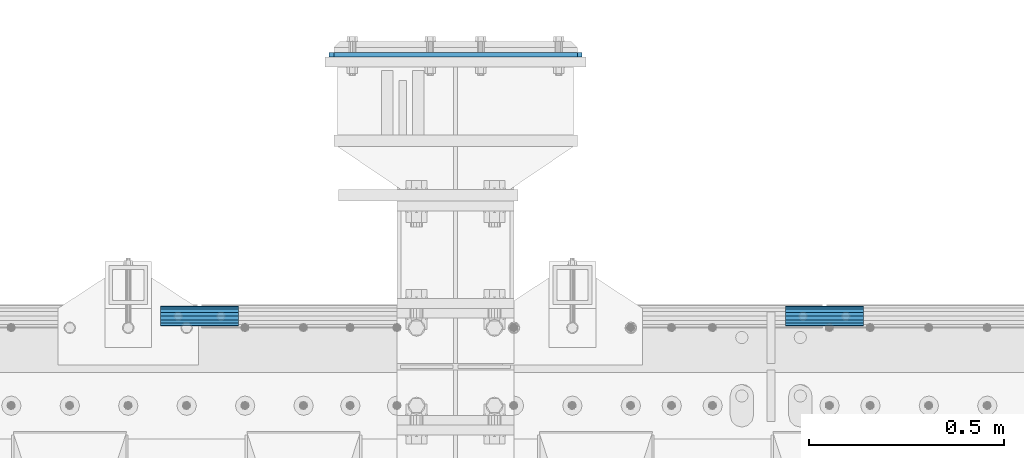
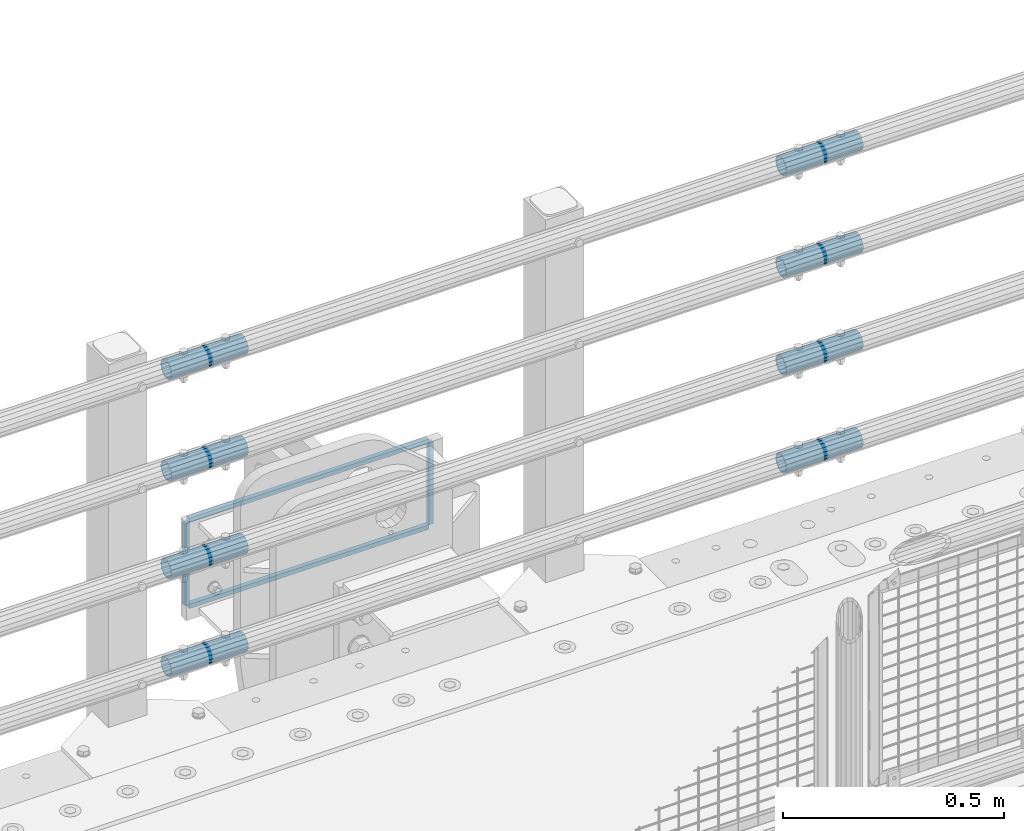
# One storey, part 165 of 240: 12 beams.
"""IFC2X3 building model written with IfcOpenShell, lengths in millimetres."""

from ifc_helpers import new_model, si_unit, frame, origin_with_axes, place, context, subcontext, project, spatial, faceted_brep, material, type_object, element, save


model = new_model("IFC2X3")

# Units and contexts
model_context = context("Model", 3, precision=1e-05, world=origin_with_axes())
body_context = subcontext(model_context, "Body", "Model", "MODEL_VIEW")
ifc_project = project(units=[si_unit("LENGTHUNIT", "METRE", prefix="MILLI"), si_unit("AREAUNIT", "SQUARE_METRE"), si_unit("VOLUMEUNIT", "CUBIC_METRE"), si_unit("MASSUNIT", "GRAM", prefix="KILO"), si_unit("TIMEUNIT", "SECOND"), si_unit("PLANEANGLEUNIT", "RADIAN"), si_unit("SOLIDANGLEUNIT", "STERADIAN"), si_unit("THERMODYNAMICTEMPERATUREUNIT", "DEGREE_CELSIUS"), si_unit("LUMINOUSINTENSITYUNIT", "LUMEN")], contexts=[model_context])

# Site, building, storey
site_placement = place(None, origin_with_axes())
site = spatial("IfcSite", under=ifc_project, at=site_placement, CompositionType="ELEMENT")
building_placement = place(site_placement, origin_with_axes())
building = spatial("IfcBuilding", under=site, at=building_placement, Name="Standard", CompositionType="ELEMENT")
storey_placement = place(building_placement, origin_with_axes())
storey = spatial("IfcBuildingStorey", under=building, at=storey_placement, Name="Undefined", CompositionType="ELEMENT", Elevation=0.0)

# Beams
ifc_material_1 = material(Name="STEEL/S355N")
beam_type_1 = type_object("IfcBeamType", PredefinedType="NOTDEFINED")
for number, where, z_axis, x_axis in (
    (1, (52521.4999999949, 36801.0000000349, -12.5000182222742), (-1.0, 0.0, 0.0), (0.0, 0.0, -1.0)),
    (2, (53158.5, 36801.0000000345, -12.500018222274), (-1.0, 0.0, 0.0), (0.0, 0.0, -1.0)),
):
    element("IfcBeam", number, at=place(storey_placement, frame(where, z_axis=z_axis, x_axis=x_axis)), inside=storey, type_object=beam_type_1, material=ifc_material_1, context=body_context, shape_type="Brep", body=[
        faceted_brep([(0.0, 6.0, -6.0), (0.0, 6.0, 6.0), (225.0, 6.0, 6.0), (225.0, 6.0, -6.0), (0.0, -6.0, 6.0), (225.0, -6.0, 6.0), (0.0, -6.0, -6.0), (225.0, -6.0, -6.0)], [[[0, 1, 2, 3]], [[1, 4, 5, 2]], [[4, 6, 7, 5]], [[6, 0, 3, 7]], [[5, 7, 3, 2]], [[6, 4, 1, 0]]]),
    ])
for number, where, z_axis, x_axis in (
    (3, (52527.5, 36801.0000000345, -6.50001822227398), (0.0, 0.0, -1.0), (1.0, 0.0, 0.0)),
    (4, (52527.5, 36801.0000000345, -243.500018222274), (0.0, 0.0, -1.0), (1.0, 0.0, 0.0)),
):
    element("IfcBeam", number, at=place(storey_placement, frame(where, z_axis=z_axis, x_axis=x_axis)), inside=storey, type_object=beam_type_1, material=ifc_material_1, context=body_context, shape_type="Brep", body=[
        faceted_brep([(0.0, 6.0, -6.0), (0.0, 6.0, 6.0), (625.0, 6.0, 6.0), (625.0, 6.0, -6.0), (0.0, -6.0, 6.0), (625.0, -6.0, 6.0), (0.0, -6.0, -6.0), (625.0, -6.0, -6.0)], [[[0, 1, 2, 3]], [[1, 4, 5, 2]], [[4, 6, 7, 5]], [[6, 0, 3, 7]], [[5, 7, 3, 2]], [[6, 4, 1, 0]]]),
    ])
ifc_material_2 = material()
beam_type_2 = type_object("IfcBeamType", PredefinedType="NOTDEFINED")
beam_1_placement = place(storey_placement, frame((52082.9975029999, 36129.8500000004, 149.849999999747), z_axis=(0.0, 0.0, 1.0), x_axis=(1.0, 0.0, 0.0)))
element("IfcBeam", 5, at=beam_1_placement, inside=storey, type_object=beam_type_2, material=ifc_material_2, context=body_context, shape_type="Brep", body=[
    faceted_brep([(0.0, -21.9000000000015, 0.0), (0.0, -20.232961761998, 8.38076716879547), (200.0, -20.232961761998, 8.38076716879547), (200.0, -21.9000000000015, 0.0), (0.0, -15.4856385079838, 15.4856385079854), (200.0, -15.4856385079838, 15.4856385079854), (0.0, -8.38076716879732, 20.2329617619972), (200.0, -8.38076716879732, 20.2329617619972), (0.0, 0.0, 21.9), (200.0, 0.0, 21.9), (0.0, 8.38076716879732, 20.2329617619972), (200.0, 8.38076716879732, 20.2329617619972), (0.0, 15.4856385079838, 15.4856385079854), (200.0, 15.4856385079838, 15.4856385079854), (0.0, 20.232961761998, 8.38076716879547), (200.0, 20.232961761998, 8.38076716879547), (0.0, 21.9000000000015, 0.0), (200.0, 21.9000000000015, 0.0), (0.0, 20.232961761998, -8.38076716879547), (200.0, 20.232961761998, -8.38076716879547), (0.0, 15.4856385079838, -15.4856385079854), (200.0, 15.4856385079838, -15.4856385079854), (0.0, 8.38076716879732, -20.2329617619972), (200.0, 8.38076716879732, -20.2329617619972), (0.0, 0.0, -21.9), (200.0, 0.0, -21.9), (0.0, -8.38076716879732, -20.2329617619972), (200.0, -8.38076716879732, -20.2329617619972), (0.0, -15.4856385079838, -15.4856385079854), (200.0, -15.4856385079838, -15.4856385079854), (0.0, -20.232961761998, -8.38076716879547), (200.0, -20.232961761998, -8.38076716879547), (0.0, -25.5, 0.0), (0.0, -23.5589280790373, -9.7584275253098), (200.0, -23.5589280790373, -9.7584275253098), (200.0, -25.5, 0.0), (0.0, -18.0312229202536, -18.031222920257), (200.0, -18.0312229202536, -18.031222920257), (0.0, -9.75842752531025, -23.5589280790378), (200.0, -9.75842752531025, -23.5589280790378), (0.0, 0.0, -25.5), (200.0, 0.0, -25.5), (0.0, 9.75842752531025, -23.5589280790378), (200.0, 9.75842752531025, -23.5589280790378), (0.0, 18.0312229202536, -18.031222920257), (200.0, 18.0312229202536, -18.031222920257), (0.0, 23.5589280790373, -9.7584275253098), (200.0, 23.5589280790373, -9.7584275253098), (0.0, 25.5, 0.0), (200.0, 25.5, 0.0), (0.0, 23.5589280790373, 9.7584275253098), (200.0, 23.5589280790373, 9.7584275253098), (0.0, 18.0312229202536, 18.031222920257), (200.0, 18.0312229202536, 18.031222920257), (0.0, 9.75842752531025, 23.5589280790378), (200.0, 9.75842752531025, 23.5589280790378), (0.0, 0.0, 25.5), (200.0, 0.0, 25.5), (0.0, -9.75842752531025, 23.5589280790378), (200.0, -9.75842752531025, 23.5589280790378), (0.0, -18.0312229202536, 18.031222920257), (200.0, -18.0312229202536, 18.031222920257), (0.0, -23.5589280790373, 9.7584275253098), (200.0, -23.5589280790373, 9.7584275253098)], [[[0, 1, 2, 3]], [[1, 4, 5, 2]], [[4, 6, 7, 5]], [[6, 8, 9, 7]], [[8, 10, 11, 9]], [[10, 12, 13, 11]], [[12, 14, 15, 13]], [[14, 16, 17, 15]], [[16, 18, 19, 17]], [[18, 20, 21, 19]], [[20, 22, 23, 21]], [[22, 24, 25, 23]], [[24, 26, 27, 25]], [[26, 28, 29, 27]], [[28, 30, 31, 29]], [[30, 0, 3, 31]], [[32, 33, 34, 35]], [[33, 36, 37, 34]], [[36, 38, 39, 37]], [[38, 40, 41, 39]], [[40, 42, 43, 41]], [[42, 44, 45, 43]], [[44, 46, 47, 45]], [[46, 48, 49, 47]], [[48, 50, 51, 49]], [[50, 52, 53, 51]], [[52, 54, 55, 53]], [[54, 56, 57, 55]], [[56, 58, 59, 57]], [[58, 60, 61, 59]], [[60, 62, 63, 61]], [[62, 32, 35, 63]], [[37, 39, 41, 43, 45, 47, 49, 51, 53, 55, 57, 59, 61, 63, 35, 34], [5, 7, 9, 11, 13, 15, 17, 19, 21, 23, 25, 27, 29, 31, 3, 2]], [[62, 60, 58, 56, 54, 52, 50, 48, 46, 44, 42, 40, 38, 36, 33, 32], [30, 28, 26, 24, 22, 20, 18, 16, 14, 12, 10, 8, 6, 4, 1, 0]]]),
])
beam_2_placement = place(storey_placement, frame((53686.9975029999, 36129.8500000004, 149.849999999747), z_axis=(0.0, 0.0, 1.0), x_axis=(1.0, 0.0, 0.0)))
element("IfcBeam", 6, at=beam_2_placement, inside=storey, type_object=beam_type_2, material=ifc_material_2, context=body_context, shape_type="Brep", body=[
    faceted_brep([(0.0, -21.9000000000015, 0.0), (0.0, -20.232961761998, 8.38076716879547), (200.0, -20.232961761998, 8.38076716879547), (200.0, -21.9000000000015, 0.0), (0.0, -15.4856385079838, 15.4856385079854), (200.0, -15.4856385079838, 15.4856385079854), (0.0, -8.38076716879732, 20.2329617619972), (200.0, -8.38076716879732, 20.2329617619972), (0.0, 0.0, 21.9), (200.0, 0.0, 21.9), (0.0, 8.38076716879732, 20.2329617619972), (200.0, 8.38076716879732, 20.2329617619972), (0.0, 15.4856385079838, 15.4856385079854), (200.0, 15.4856385079838, 15.4856385079854), (0.0, 20.232961761998, 8.38076716879547), (200.0, 20.232961761998, 8.38076716879547), (0.0, 21.9000000000015, 0.0), (200.0, 21.9000000000015, 0.0), (0.0, 20.232961761998, -8.38076716879547), (200.0, 20.232961761998, -8.38076716879547), (0.0, 15.4856385079838, -15.4856385079854), (200.0, 15.4856385079838, -15.4856385079854), (0.0, 8.38076716879732, -20.2329617619972), (200.0, 8.38076716879732, -20.2329617619972), (0.0, 0.0, -21.9), (200.0, 0.0, -21.9), (0.0, -8.38076716879732, -20.2329617619972), (200.0, -8.38076716879732, -20.2329617619972), (0.0, -15.4856385079838, -15.4856385079854), (200.0, -15.4856385079838, -15.4856385079854), (0.0, -20.232961761998, -8.38076716879547), (200.0, -20.232961761998, -8.38076716879547), (0.0, -25.5, 0.0), (0.0, -23.5589280790373, -9.7584275253098), (200.0, -23.5589280790373, -9.7584275253098), (200.0, -25.5, 0.0), (0.0, -18.0312229202536, -18.031222920257), (200.0, -18.0312229202536, -18.031222920257), (0.0, -9.75842752531025, -23.5589280790378), (200.0, -9.75842752531025, -23.5589280790378), (0.0, 0.0, -25.5), (200.0, 0.0, -25.5), (0.0, 9.75842752531025, -23.5589280790378), (200.0, 9.75842752531025, -23.5589280790378), (0.0, 18.0312229202536, -18.031222920257), (200.0, 18.0312229202536, -18.031222920257), (0.0, 23.5589280790373, -9.7584275253098), (200.0, 23.5589280790373, -9.7584275253098), (0.0, 25.5, 0.0), (200.0, 25.5, 0.0), (0.0, 23.5589280790373, 9.7584275253098), (200.0, 23.5589280790373, 9.7584275253098), (0.0, 18.0312229202536, 18.031222920257), (200.0, 18.0312229202536, 18.031222920257), (0.0, 9.75842752531025, 23.5589280790378), (200.0, 9.75842752531025, 23.5589280790378), (0.0, 0.0, 25.5), (200.0, 0.0, 25.5), (0.0, -9.75842752531025, 23.5589280790378), (200.0, -9.75842752531025, 23.5589280790378), (0.0, -18.0312229202536, 18.031222920257), (200.0, -18.0312229202536, 18.031222920257), (0.0, -23.5589280790373, 9.7584275253098), (200.0, -23.5589280790373, 9.7584275253098)], [[[0, 1, 2, 3]], [[1, 4, 5, 2]], [[4, 6, 7, 5]], [[6, 8, 9, 7]], [[8, 10, 11, 9]], [[10, 12, 13, 11]], [[12, 14, 15, 13]], [[14, 16, 17, 15]], [[16, 18, 19, 17]], [[18, 20, 21, 19]], [[20, 22, 23, 21]], [[22, 24, 25, 23]], [[24, 26, 27, 25]], [[26, 28, 29, 27]], [[28, 30, 31, 29]], [[30, 0, 3, 31]], [[32, 33, 34, 35]], [[33, 36, 37, 34]], [[36, 38, 39, 37]], [[38, 40, 41, 39]], [[40, 42, 43, 41]], [[42, 44, 45, 43]], [[44, 46, 47, 45]], [[46, 48, 49, 47]], [[48, 50, 51, 49]], [[50, 52, 53, 51]], [[52, 54, 55, 53]], [[54, 56, 57, 55]], [[56, 58, 59, 57]], [[58, 60, 61, 59]], [[60, 62, 63, 61]], [[62, 32, 35, 63]], [[37, 39, 41, 43, 45, 47, 49, 51, 53, 55, 57, 59, 61, 63, 35, 34], [5, 7, 9, 11, 13, 15, 17, 19, 21, 23, 25, 27, 29, 31, 3, 2]], [[62, 60, 58, 56, 54, 52, 50, 48, 46, 44, 42, 40, 38, 36, 33, 32], [30, 28, 26, 24, 22, 20, 18, 16, 14, 12, 10, 8, 6, 4, 1, 0]]]),
])
beam_3_placement = place(storey_placement, frame((52082.9975029999, 36129.8500000004, 420.149999999747), z_axis=(0.0, 0.0, 1.0), x_axis=(1.0, 0.0, 0.0)))
element("IfcBeam", 7, at=beam_3_placement, inside=storey, type_object=beam_type_2, material=ifc_material_2, context=body_context, shape_type="Brep", body=[
    faceted_brep([(0.0, -21.9000000000015, 0.0), (0.0, -20.232961761998, 8.38076716879547), (200.0, -20.232961761998, 8.38076716879547), (200.0, -21.9000000000015, 0.0), (0.0, -15.4856385079838, 15.4856385079854), (200.0, -15.4856385079838, 15.4856385079854), (0.0, -8.38076716879732, 20.2329617619972), (200.0, -8.38076716879732, 20.2329617619972), (0.0, 0.0, 21.9), (200.0, 0.0, 21.9), (0.0, 8.38076716879732, 20.2329617619972), (200.0, 8.38076716879732, 20.2329617619972), (0.0, 15.4856385079838, 15.4856385079854), (200.0, 15.4856385079838, 15.4856385079854), (0.0, 20.232961761998, 8.38076716879547), (200.0, 20.232961761998, 8.38076716879547), (0.0, 21.9000000000015, 0.0), (200.0, 21.9000000000015, 0.0), (0.0, 20.232961761998, -8.38076716879547), (200.0, 20.232961761998, -8.38076716879547), (0.0, 15.4856385079838, -15.4856385079854), (200.0, 15.4856385079838, -15.4856385079854), (0.0, 8.38076716879732, -20.2329617619972), (200.0, 8.38076716879732, -20.2329617619972), (0.0, 0.0, -21.9), (200.0, 0.0, -21.9), (0.0, -8.38076716879732, -20.2329617619972), (200.0, -8.38076716879732, -20.2329617619972), (0.0, -15.4856385079838, -15.4856385079854), (200.0, -15.4856385079838, -15.4856385079854), (0.0, -20.232961761998, -8.38076716879547), (200.0, -20.232961761998, -8.38076716879547), (0.0, -25.5, 0.0), (0.0, -23.5589280790373, -9.7584275253098), (200.0, -23.5589280790373, -9.7584275253098), (200.0, -25.5, 0.0), (0.0, -18.0312229202536, -18.031222920257), (200.0, -18.0312229202536, -18.031222920257), (0.0, -9.75842752531025, -23.5589280790378), (200.0, -9.75842752531025, -23.5589280790378), (0.0, 0.0, -25.5), (200.0, 0.0, -25.5), (0.0, 9.75842752531025, -23.5589280790378), (200.0, 9.75842752531025, -23.5589280790378), (0.0, 18.0312229202536, -18.031222920257), (200.0, 18.0312229202536, -18.031222920257), (0.0, 23.5589280790373, -9.7584275253098), (200.0, 23.5589280790373, -9.7584275253098), (0.0, 25.5, 0.0), (200.0, 25.5, 0.0), (0.0, 23.5589280790373, 9.7584275253098), (200.0, 23.5589280790373, 9.7584275253098), (0.0, 18.0312229202536, 18.031222920257), (200.0, 18.0312229202536, 18.031222920257), (0.0, 9.75842752531025, 23.5589280790378), (200.0, 9.75842752531025, 23.5589280790378), (0.0, 0.0, 25.5), (200.0, 0.0, 25.5), (0.0, -9.75842752531025, 23.5589280790378), (200.0, -9.75842752531025, 23.5589280790378), (0.0, -18.0312229202536, 18.031222920257), (200.0, -18.0312229202536, 18.031222920257), (0.0, -23.5589280790373, 9.7584275253098), (200.0, -23.5589280790373, 9.7584275253098)], [[[0, 1, 2, 3]], [[1, 4, 5, 2]], [[4, 6, 7, 5]], [[6, 8, 9, 7]], [[8, 10, 11, 9]], [[10, 12, 13, 11]], [[12, 14, 15, 13]], [[14, 16, 17, 15]], [[16, 18, 19, 17]], [[18, 20, 21, 19]], [[20, 22, 23, 21]], [[22, 24, 25, 23]], [[24, 26, 27, 25]], [[26, 28, 29, 27]], [[28, 30, 31, 29]], [[30, 0, 3, 31]], [[32, 33, 34, 35]], [[33, 36, 37, 34]], [[36, 38, 39, 37]], [[38, 40, 41, 39]], [[40, 42, 43, 41]], [[42, 44, 45, 43]], [[44, 46, 47, 45]], [[46, 48, 49, 47]], [[48, 50, 51, 49]], [[50, 52, 53, 51]], [[52, 54, 55, 53]], [[54, 56, 57, 55]], [[56, 58, 59, 57]], [[58, 60, 61, 59]], [[60, 62, 63, 61]], [[62, 32, 35, 63]], [[37, 39, 41, 43, 45, 47, 49, 51, 53, 55, 57, 59, 61, 63, 35, 34], [5, 7, 9, 11, 13, 15, 17, 19, 21, 23, 25, 27, 29, 31, 3, 2]], [[62, 60, 58, 56, 54, 52, 50, 48, 46, 44, 42, 40, 38, 36, 33, 32], [30, 28, 26, 24, 22, 20, 18, 16, 14, 12, 10, 8, 6, 4, 1, 0]]]),
])
beam_4_placement = place(storey_placement, frame((53686.9975029999, 36129.8500000004, 420.149999999747), z_axis=(0.0, 0.0, 1.0), x_axis=(1.0, 0.0, 0.0)))
element("IfcBeam", 8, at=beam_4_placement, inside=storey, type_object=beam_type_2, material=ifc_material_2, context=body_context, shape_type="Brep", body=[
    faceted_brep([(0.0, -21.9000000000015, 0.0), (0.0, -20.232961761998, 8.38076716879547), (200.0, -20.232961761998, 8.38076716879547), (200.0, -21.9000000000015, 0.0), (0.0, -15.4856385079838, 15.4856385079854), (200.0, -15.4856385079838, 15.4856385079854), (0.0, -8.38076716879732, 20.2329617619972), (200.0, -8.38076716879732, 20.2329617619972), (0.0, 0.0, 21.9), (200.0, 0.0, 21.9), (0.0, 8.38076716879732, 20.2329617619972), (200.0, 8.38076716879732, 20.2329617619972), (0.0, 15.4856385079838, 15.4856385079854), (200.0, 15.4856385079838, 15.4856385079854), (0.0, 20.232961761998, 8.38076716879547), (200.0, 20.232961761998, 8.38076716879547), (0.0, 21.9000000000015, 0.0), (200.0, 21.9000000000015, 0.0), (0.0, 20.232961761998, -8.38076716879547), (200.0, 20.232961761998, -8.38076716879547), (0.0, 15.4856385079838, -15.4856385079854), (200.0, 15.4856385079838, -15.4856385079854), (0.0, 8.38076716879732, -20.2329617619972), (200.0, 8.38076716879732, -20.2329617619972), (0.0, 0.0, -21.9), (200.0, 0.0, -21.9), (0.0, -8.38076716879732, -20.2329617619972), (200.0, -8.38076716879732, -20.2329617619972), (0.0, -15.4856385079838, -15.4856385079854), (200.0, -15.4856385079838, -15.4856385079854), (0.0, -20.232961761998, -8.38076716879547), (200.0, -20.232961761998, -8.38076716879547), (0.0, -25.5, 0.0), (0.0, -23.5589280790373, -9.7584275253098), (200.0, -23.5589280790373, -9.7584275253098), (200.0, -25.5, 0.0), (0.0, -18.0312229202536, -18.031222920257), (200.0, -18.0312229202536, -18.031222920257), (0.0, -9.75842752531025, -23.5589280790378), (200.0, -9.75842752531025, -23.5589280790378), (0.0, 0.0, -25.5), (200.0, 0.0, -25.5), (0.0, 9.75842752531025, -23.5589280790378), (200.0, 9.75842752531025, -23.5589280790378), (0.0, 18.0312229202536, -18.031222920257), (200.0, 18.0312229202536, -18.031222920257), (0.0, 23.5589280790373, -9.7584275253098), (200.0, 23.5589280790373, -9.7584275253098), (0.0, 25.5, 0.0), (200.0, 25.5, 0.0), (0.0, 23.5589280790373, 9.7584275253098), (200.0, 23.5589280790373, 9.7584275253098), (0.0, 18.0312229202536, 18.031222920257), (200.0, 18.0312229202536, 18.031222920257), (0.0, 9.75842752531025, 23.5589280790378), (200.0, 9.75842752531025, 23.5589280790378), (0.0, 0.0, 25.5), (200.0, 0.0, 25.5), (0.0, -9.75842752531025, 23.5589280790378), (200.0, -9.75842752531025, 23.5589280790378), (0.0, -18.0312229202536, 18.031222920257), (200.0, -18.0312229202536, 18.031222920257), (0.0, -23.5589280790373, 9.7584275253098), (200.0, -23.5589280790373, 9.7584275253098)], [[[0, 1, 2, 3]], [[1, 4, 5, 2]], [[4, 6, 7, 5]], [[6, 8, 9, 7]], [[8, 10, 11, 9]], [[10, 12, 13, 11]], [[12, 14, 15, 13]], [[14, 16, 17, 15]], [[16, 18, 19, 17]], [[18, 20, 21, 19]], [[20, 22, 23, 21]], [[22, 24, 25, 23]], [[24, 26, 27, 25]], [[26, 28, 29, 27]], [[28, 30, 31, 29]], [[30, 0, 3, 31]], [[32, 33, 34, 35]], [[33, 36, 37, 34]], [[36, 38, 39, 37]], [[38, 40, 41, 39]], [[40, 42, 43, 41]], [[42, 44, 45, 43]], [[44, 46, 47, 45]], [[46, 48, 49, 47]], [[48, 50, 51, 49]], [[50, 52, 53, 51]], [[52, 54, 55, 53]], [[54, 56, 57, 55]], [[56, 58, 59, 57]], [[58, 60, 61, 59]], [[60, 62, 63, 61]], [[62, 32, 35, 63]], [[37, 39, 41, 43, 45, 47, 49, 51, 53, 55, 57, 59, 61, 63, 35, 34], [5, 7, 9, 11, 13, 15, 17, 19, 21, 23, 25, 27, 29, 31, 3, 2]], [[62, 60, 58, 56, 54, 52, 50, 48, 46, 44, 42, 40, 38, 36, 33, 32], [30, 28, 26, 24, 22, 20, 18, 16, 14, 12, 10, 8, 6, 4, 1, 0]]]),
])
beam_5_placement = place(storey_placement, frame((52082.9975029999, 36129.8500000004, 969.849999999747), z_axis=(0.0, 0.0, 1.0), x_axis=(1.0, 0.0, 0.0)))
element("IfcBeam", 9, at=beam_5_placement, inside=storey, type_object=beam_type_2, material=ifc_material_2, context=body_context, shape_type="Brep", body=[
    faceted_brep([(0.0, -21.9000000000015, 0.0), (0.0, -20.232961761998, 8.38076716879547), (200.0, -20.232961761998, 8.38076716879547), (200.0, -21.9000000000015, 0.0), (0.0, -15.4856385079838, 15.4856385079854), (200.0, -15.4856385079838, 15.4856385079854), (0.0, -8.38076716879732, 20.2329617619972), (200.0, -8.38076716879732, 20.2329617619972), (0.0, 0.0, 21.9), (200.0, 0.0, 21.9), (0.0, 8.38076716879732, 20.2329617619972), (200.0, 8.38076716879732, 20.2329617619972), (0.0, 15.4856385079838, 15.4856385079854), (200.0, 15.4856385079838, 15.4856385079854), (0.0, 20.232961761998, 8.38076716879547), (200.0, 20.232961761998, 8.38076716879547), (0.0, 21.9000000000015, 0.0), (200.0, 21.9000000000015, 0.0), (0.0, 20.232961761998, -8.38076716879547), (200.0, 20.232961761998, -8.38076716879547), (0.0, 15.4856385079838, -15.4856385079854), (200.0, 15.4856385079838, -15.4856385079854), (0.0, 8.38076716879732, -20.2329617619972), (200.0, 8.38076716879732, -20.2329617619972), (0.0, 0.0, -21.9), (200.0, 0.0, -21.9), (0.0, -8.38076716879732, -20.2329617619972), (200.0, -8.38076716879732, -20.2329617619972), (0.0, -15.4856385079838, -15.4856385079854), (200.0, -15.4856385079838, -15.4856385079854), (0.0, -20.232961761998, -8.38076716879547), (200.0, -20.232961761998, -8.38076716879547), (0.0, -25.5, 0.0), (0.0, -23.5589280790373, -9.7584275253098), (200.0, -23.5589280790373, -9.7584275253098), (200.0, -25.5, 0.0), (0.0, -18.0312229202536, -18.031222920257), (200.0, -18.0312229202536, -18.031222920257), (0.0, -9.75842752531025, -23.5589280790378), (200.0, -9.75842752531025, -23.5589280790378), (0.0, 0.0, -25.5), (200.0, 0.0, -25.5), (0.0, 9.75842752531025, -23.5589280790378), (200.0, 9.75842752531025, -23.5589280790378), (0.0, 18.0312229202536, -18.031222920257), (200.0, 18.0312229202536, -18.031222920257), (0.0, 23.5589280790373, -9.7584275253098), (200.0, 23.5589280790373, -9.7584275253098), (0.0, 25.5, 0.0), (200.0, 25.5, 0.0), (0.0, 23.5589280790373, 9.7584275253098), (200.0, 23.5589280790373, 9.7584275253098), (0.0, 18.0312229202536, 18.031222920257), (200.0, 18.0312229202536, 18.031222920257), (0.0, 9.75842752531025, 23.5589280790378), (200.0, 9.75842752531025, 23.5589280790378), (0.0, 0.0, 25.5), (200.0, 0.0, 25.5), (0.0, -9.75842752531025, 23.5589280790378), (200.0, -9.75842752531025, 23.5589280790378), (0.0, -18.0312229202536, 18.031222920257), (200.0, -18.0312229202536, 18.031222920257), (0.0, -23.5589280790373, 9.7584275253098), (200.0, -23.5589280790373, 9.7584275253098)], [[[0, 1, 2, 3]], [[1, 4, 5, 2]], [[4, 6, 7, 5]], [[6, 8, 9, 7]], [[8, 10, 11, 9]], [[10, 12, 13, 11]], [[12, 14, 15, 13]], [[14, 16, 17, 15]], [[16, 18, 19, 17]], [[18, 20, 21, 19]], [[20, 22, 23, 21]], [[22, 24, 25, 23]], [[24, 26, 27, 25]], [[26, 28, 29, 27]], [[28, 30, 31, 29]], [[30, 0, 3, 31]], [[32, 33, 34, 35]], [[33, 36, 37, 34]], [[36, 38, 39, 37]], [[38, 40, 41, 39]], [[40, 42, 43, 41]], [[42, 44, 45, 43]], [[44, 46, 47, 45]], [[46, 48, 49, 47]], [[48, 50, 51, 49]], [[50, 52, 53, 51]], [[52, 54, 55, 53]], [[54, 56, 57, 55]], [[56, 58, 59, 57]], [[58, 60, 61, 59]], [[60, 62, 63, 61]], [[62, 32, 35, 63]], [[37, 39, 41, 43, 45, 47, 49, 51, 53, 55, 57, 59, 61, 63, 35, 34], [5, 7, 9, 11, 13, 15, 17, 19, 21, 23, 25, 27, 29, 31, 3, 2]], [[62, 60, 58, 56, 54, 52, 50, 48, 46, 44, 42, 40, 38, 36, 33, 32], [30, 28, 26, 24, 22, 20, 18, 16, 14, 12, 10, 8, 6, 4, 1, 0]]]),
])
beam_6_placement = place(storey_placement, frame((53686.9975029999, 36129.8500000004, 969.849999999747), z_axis=(0.0, 0.0, 1.0), x_axis=(1.0, 0.0, 0.0)))
element("IfcBeam", 10, at=beam_6_placement, inside=storey, type_object=beam_type_2, material=ifc_material_2, context=body_context, shape_type="Brep", body=[
    faceted_brep([(0.0, -21.9000000000015, 0.0), (0.0, -20.232961761998, 8.38076716879547), (200.0, -20.232961761998, 8.38076716879547), (200.0, -21.9000000000015, 0.0), (0.0, -15.4856385079838, 15.4856385079854), (200.0, -15.4856385079838, 15.4856385079854), (0.0, -8.38076716879732, 20.2329617619972), (200.0, -8.38076716879732, 20.2329617619972), (0.0, 0.0, 21.9), (200.0, 0.0, 21.9), (0.0, 8.38076716879732, 20.2329617619972), (200.0, 8.38076716879732, 20.2329617619972), (0.0, 15.4856385079838, 15.4856385079854), (200.0, 15.4856385079838, 15.4856385079854), (0.0, 20.232961761998, 8.38076716879547), (200.0, 20.232961761998, 8.38076716879547), (0.0, 21.9000000000015, 0.0), (200.0, 21.9000000000015, 0.0), (0.0, 20.232961761998, -8.38076716879547), (200.0, 20.232961761998, -8.38076716879547), (0.0, 15.4856385079838, -15.4856385079854), (200.0, 15.4856385079838, -15.4856385079854), (0.0, 8.38076716879732, -20.2329617619972), (200.0, 8.38076716879732, -20.2329617619972), (0.0, 0.0, -21.9), (200.0, 0.0, -21.9), (0.0, -8.38076716879732, -20.2329617619972), (200.0, -8.38076716879732, -20.2329617619972), (0.0, -15.4856385079838, -15.4856385079854), (200.0, -15.4856385079838, -15.4856385079854), (0.0, -20.232961761998, -8.38076716879547), (200.0, -20.232961761998, -8.38076716879547), (0.0, -25.5, 0.0), (0.0, -23.5589280790373, -9.7584275253098), (200.0, -23.5589280790373, -9.7584275253098), (200.0, -25.5, 0.0), (0.0, -18.0312229202536, -18.031222920257), (200.0, -18.0312229202536, -18.031222920257), (0.0, -9.75842752531025, -23.5589280790378), (200.0, -9.75842752531025, -23.5589280790378), (0.0, 0.0, -25.5), (200.0, 0.0, -25.5), (0.0, 9.75842752531025, -23.5589280790378), (200.0, 9.75842752531025, -23.5589280790378), (0.0, 18.0312229202536, -18.031222920257), (200.0, 18.0312229202536, -18.031222920257), (0.0, 23.5589280790373, -9.7584275253098), (200.0, 23.5589280790373, -9.7584275253098), (0.0, 25.5, 0.0), (200.0, 25.5, 0.0), (0.0, 23.5589280790373, 9.7584275253098), (200.0, 23.5589280790373, 9.7584275253098), (0.0, 18.0312229202536, 18.031222920257), (200.0, 18.0312229202536, 18.031222920257), (0.0, 9.75842752531025, 23.5589280790378), (200.0, 9.75842752531025, 23.5589280790378), (0.0, 0.0, 25.5), (200.0, 0.0, 25.5), (0.0, -9.75842752531025, 23.5589280790378), (200.0, -9.75842752531025, 23.5589280790378), (0.0, -18.0312229202536, 18.031222920257), (200.0, -18.0312229202536, 18.031222920257), (0.0, -23.5589280790373, 9.7584275253098), (200.0, -23.5589280790373, 9.7584275253098)], [[[0, 1, 2, 3]], [[1, 4, 5, 2]], [[4, 6, 7, 5]], [[6, 8, 9, 7]], [[8, 10, 11, 9]], [[10, 12, 13, 11]], [[12, 14, 15, 13]], [[14, 16, 17, 15]], [[16, 18, 19, 17]], [[18, 20, 21, 19]], [[20, 22, 23, 21]], [[22, 24, 25, 23]], [[24, 26, 27, 25]], [[26, 28, 29, 27]], [[28, 30, 31, 29]], [[30, 0, 3, 31]], [[32, 33, 34, 35]], [[33, 36, 37, 34]], [[36, 38, 39, 37]], [[38, 40, 41, 39]], [[40, 42, 43, 41]], [[42, 44, 45, 43]], [[44, 46, 47, 45]], [[46, 48, 49, 47]], [[48, 50, 51, 49]], [[50, 52, 53, 51]], [[52, 54, 55, 53]], [[54, 56, 57, 55]], [[56, 58, 59, 57]], [[58, 60, 61, 59]], [[60, 62, 63, 61]], [[62, 32, 35, 63]], [[37, 39, 41, 43, 45, 47, 49, 51, 53, 55, 57, 59, 61, 63, 35, 34], [5, 7, 9, 11, 13, 15, 17, 19, 21, 23, 25, 27, 29, 31, 3, 2]], [[62, 60, 58, 56, 54, 52, 50, 48, 46, 44, 42, 40, 38, 36, 33, 32], [30, 28, 26, 24, 22, 20, 18, 16, 14, 12, 10, 8, 6, 4, 1, 0]]]),
])
beam_7_placement = place(storey_placement, frame((52082.9975029999, 36129.8500000004, 689.849999999747), z_axis=(0.0, 0.0, 1.0), x_axis=(1.0, 0.0, 0.0)))
element("IfcBeam", 11, at=beam_7_placement, inside=storey, type_object=beam_type_2, material=ifc_material_2, context=body_context, shape_type="Brep", body=[
    faceted_brep([(0.0, -21.9000000000015, 0.0), (0.0, -20.232961761998, 8.38076716879547), (200.0, -20.232961761998, 8.38076716879547), (200.0, -21.9000000000015, 0.0), (0.0, -15.4856385079838, 15.4856385079854), (200.0, -15.4856385079838, 15.4856385079854), (0.0, -8.38076716879732, 20.2329617619972), (200.0, -8.38076716879732, 20.2329617619972), (0.0, 0.0, 21.9), (200.0, 0.0, 21.9), (0.0, 8.38076716879732, 20.2329617619972), (200.0, 8.38076716879732, 20.2329617619972), (0.0, 15.4856385079838, 15.4856385079854), (200.0, 15.4856385079838, 15.4856385079854), (0.0, 20.232961761998, 8.38076716879547), (200.0, 20.232961761998, 8.38076716879547), (0.0, 21.9000000000015, 0.0), (200.0, 21.9000000000015, 0.0), (0.0, 20.232961761998, -8.38076716879547), (200.0, 20.232961761998, -8.38076716879547), (0.0, 15.4856385079838, -15.4856385079854), (200.0, 15.4856385079838, -15.4856385079854), (0.0, 8.38076716879732, -20.2329617619972), (200.0, 8.38076716879732, -20.2329617619972), (0.0, 0.0, -21.9), (200.0, 0.0, -21.9), (0.0, -8.38076716879732, -20.2329617619972), (200.0, -8.38076716879732, -20.2329617619972), (0.0, -15.4856385079838, -15.4856385079854), (200.0, -15.4856385079838, -15.4856385079854), (0.0, -20.232961761998, -8.38076716879547), (200.0, -20.232961761998, -8.38076716879547), (0.0, -25.5, 0.0), (0.0, -23.5589280790373, -9.7584275253098), (200.0, -23.5589280790373, -9.7584275253098), (200.0, -25.5, 0.0), (0.0, -18.0312229202536, -18.031222920257), (200.0, -18.0312229202536, -18.031222920257), (0.0, -9.75842752531025, -23.5589280790378), (200.0, -9.75842752531025, -23.5589280790378), (0.0, 0.0, -25.5), (200.0, 0.0, -25.5), (0.0, 9.75842752531025, -23.5589280790378), (200.0, 9.75842752531025, -23.5589280790378), (0.0, 18.0312229202536, -18.031222920257), (200.0, 18.0312229202536, -18.031222920257), (0.0, 23.5589280790373, -9.7584275253098), (200.0, 23.5589280790373, -9.7584275253098), (0.0, 25.5, 0.0), (200.0, 25.5, 0.0), (0.0, 23.5589280790373, 9.7584275253098), (200.0, 23.5589280790373, 9.7584275253098), (0.0, 18.0312229202536, 18.031222920257), (200.0, 18.0312229202536, 18.031222920257), (0.0, 9.75842752531025, 23.5589280790378), (200.0, 9.75842752531025, 23.5589280790378), (0.0, 0.0, 25.5), (200.0, 0.0, 25.5), (0.0, -9.75842752531025, 23.5589280790378), (200.0, -9.75842752531025, 23.5589280790378), (0.0, -18.0312229202536, 18.031222920257), (200.0, -18.0312229202536, 18.031222920257), (0.0, -23.5589280790373, 9.7584275253098), (200.0, -23.5589280790373, 9.7584275253098)], [[[0, 1, 2, 3]], [[1, 4, 5, 2]], [[4, 6, 7, 5]], [[6, 8, 9, 7]], [[8, 10, 11, 9]], [[10, 12, 13, 11]], [[12, 14, 15, 13]], [[14, 16, 17, 15]], [[16, 18, 19, 17]], [[18, 20, 21, 19]], [[20, 22, 23, 21]], [[22, 24, 25, 23]], [[24, 26, 27, 25]], [[26, 28, 29, 27]], [[28, 30, 31, 29]], [[30, 0, 3, 31]], [[32, 33, 34, 35]], [[33, 36, 37, 34]], [[36, 38, 39, 37]], [[38, 40, 41, 39]], [[40, 42, 43, 41]], [[42, 44, 45, 43]], [[44, 46, 47, 45]], [[46, 48, 49, 47]], [[48, 50, 51, 49]], [[50, 52, 53, 51]], [[52, 54, 55, 53]], [[54, 56, 57, 55]], [[56, 58, 59, 57]], [[58, 60, 61, 59]], [[60, 62, 63, 61]], [[62, 32, 35, 63]], [[37, 39, 41, 43, 45, 47, 49, 51, 53, 55, 57, 59, 61, 63, 35, 34], [5, 7, 9, 11, 13, 15, 17, 19, 21, 23, 25, 27, 29, 31, 3, 2]], [[62, 60, 58, 56, 54, 52, 50, 48, 46, 44, 42, 40, 38, 36, 33, 32], [30, 28, 26, 24, 22, 20, 18, 16, 14, 12, 10, 8, 6, 4, 1, 0]]]),
])
beam_8_placement = place(storey_placement, frame((53686.9975029999, 36129.8500000004, 689.849999999747), z_axis=(0.0, 0.0, 1.0), x_axis=(1.0, 0.0, 0.0)))
element("IfcBeam", 12, at=beam_8_placement, inside=storey, type_object=beam_type_2, material=ifc_material_2, context=body_context, shape_type="Brep", body=[
    faceted_brep([(0.0, -21.9000000000015, 0.0), (0.0, -20.232961761998, 8.38076716879547), (200.0, -20.232961761998, 8.38076716879547), (200.0, -21.9000000000015, 0.0), (0.0, -15.4856385079838, 15.4856385079854), (200.0, -15.4856385079838, 15.4856385079854), (0.0, -8.38076716879732, 20.2329617619972), (200.0, -8.38076716879732, 20.2329617619972), (0.0, 0.0, 21.9), (200.0, 0.0, 21.9), (0.0, 8.38076716879732, 20.2329617619972), (200.0, 8.38076716879732, 20.2329617619972), (0.0, 15.4856385079838, 15.4856385079854), (200.0, 15.4856385079838, 15.4856385079854), (0.0, 20.232961761998, 8.38076716879547), (200.0, 20.232961761998, 8.38076716879547), (0.0, 21.9000000000015, 0.0), (200.0, 21.9000000000015, 0.0), (0.0, 20.232961761998, -8.38076716879547), (200.0, 20.232961761998, -8.38076716879547), (0.0, 15.4856385079838, -15.4856385079854), (200.0, 15.4856385079838, -15.4856385079854), (0.0, 8.38076716879732, -20.2329617619972), (200.0, 8.38076716879732, -20.2329617619972), (0.0, 0.0, -21.9), (200.0, 0.0, -21.9), (0.0, -8.38076716879732, -20.2329617619972), (200.0, -8.38076716879732, -20.2329617619972), (0.0, -15.4856385079838, -15.4856385079854), (200.0, -15.4856385079838, -15.4856385079854), (0.0, -20.232961761998, -8.38076716879547), (200.0, -20.232961761998, -8.38076716879547), (0.0, -25.5, 0.0), (0.0, -23.5589280790373, -9.7584275253098), (200.0, -23.5589280790373, -9.7584275253098), (200.0, -25.5, 0.0), (0.0, -18.0312229202536, -18.031222920257), (200.0, -18.0312229202536, -18.031222920257), (0.0, -9.75842752531025, -23.5589280790378), (200.0, -9.75842752531025, -23.5589280790378), (0.0, 0.0, -25.5), (200.0, 0.0, -25.5), (0.0, 9.75842752531025, -23.5589280790378), (200.0, 9.75842752531025, -23.5589280790378), (0.0, 18.0312229202536, -18.031222920257), (200.0, 18.0312229202536, -18.031222920257), (0.0, 23.5589280790373, -9.7584275253098), (200.0, 23.5589280790373, -9.7584275253098), (0.0, 25.5, 0.0), (200.0, 25.5, 0.0), (0.0, 23.5589280790373, 9.7584275253098), (200.0, 23.5589280790373, 9.7584275253098), (0.0, 18.0312229202536, 18.031222920257), (200.0, 18.0312229202536, 18.031222920257), (0.0, 9.75842752531025, 23.5589280790378), (200.0, 9.75842752531025, 23.5589280790378), (0.0, 0.0, 25.5), (200.0, 0.0, 25.5), (0.0, -9.75842752531025, 23.5589280790378), (200.0, -9.75842752531025, 23.5589280790378), (0.0, -18.0312229202536, 18.031222920257), (200.0, -18.0312229202536, 18.031222920257), (0.0, -23.5589280790373, 9.7584275253098), (200.0, -23.5589280790373, 9.7584275253098)], [[[0, 1, 2, 3]], [[1, 4, 5, 2]], [[4, 6, 7, 5]], [[6, 8, 9, 7]], [[8, 10, 11, 9]], [[10, 12, 13, 11]], [[12, 14, 15, 13]], [[14, 16, 17, 15]], [[16, 18, 19, 17]], [[18, 20, 21, 19]], [[20, 22, 23, 21]], [[22, 24, 25, 23]], [[24, 26, 27, 25]], [[26, 28, 29, 27]], [[28, 30, 31, 29]], [[30, 0, 3, 31]], [[32, 33, 34, 35]], [[33, 36, 37, 34]], [[36, 38, 39, 37]], [[38, 40, 41, 39]], [[40, 42, 43, 41]], [[42, 44, 45, 43]], [[44, 46, 47, 45]], [[46, 48, 49, 47]], [[48, 50, 51, 49]], [[50, 52, 53, 51]], [[52, 54, 55, 53]], [[54, 56, 57, 55]], [[56, 58, 59, 57]], [[58, 60, 61, 59]], [[60, 62, 63, 61]], [[62, 32, 35, 63]], [[37, 39, 41, 43, 45, 47, 49, 51, 53, 55, 57, 59, 61, 63, 35, 34], [5, 7, 9, 11, 13, 15, 17, 19, 21, 23, 25, 27, 29, 31, 3, 2]], [[62, 60, 58, 56, 54, 52, 50, 48, 46, 44, 42, 40, 38, 36, 33, 32], [30, 28, 26, 24, 22, 20, 18, 16, 14, 12, 10, 8, 6, 4, 1, 0]]]),
])

save(model, "model.ifc")
